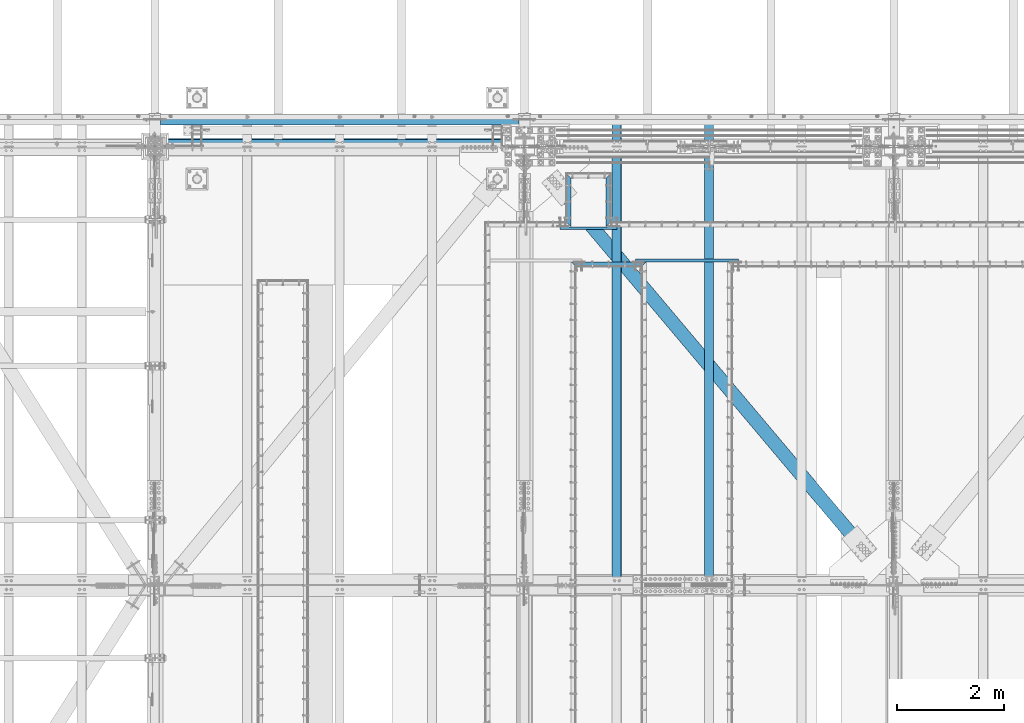
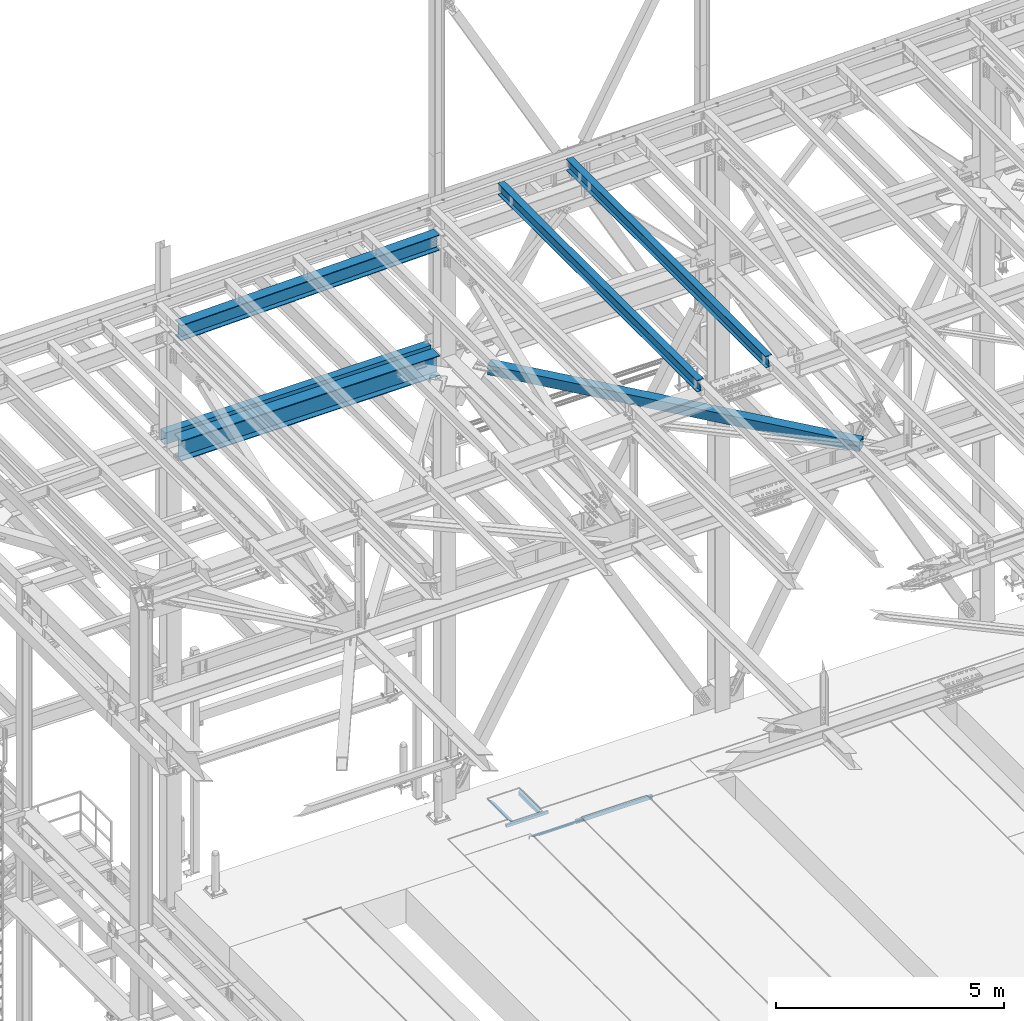
# One storey, part 1913 of 3843: 11 beams, 11 elements without a shape of their own.
"""IFC2X3 building model written with IfcOpenShell, lengths in millimetres."""

from ifc_helpers import new_model, si_unit, frame, origin_with_axes, place, context, subcontext, project, spatial, faceted_brep, material, type_object, element, aggregate, save


model = new_model("IFC2X3")

# Units and contexts
model_context = context("Model", 3, precision=1e-05, world=origin_with_axes())
body_context = subcontext(model_context, "Body", "Model", "MODEL_VIEW")
ifc_project = project(units=[si_unit("LENGTHUNIT", "METRE", prefix="MILLI"), si_unit("AREAUNIT", "SQUARE_METRE"), si_unit("VOLUMEUNIT", "CUBIC_METRE"), si_unit("MASSUNIT", "GRAM", prefix="KILO"), si_unit("TIMEUNIT", "SECOND"), si_unit("PLANEANGLEUNIT", "RADIAN"), si_unit("SOLIDANGLEUNIT", "STERADIAN"), si_unit("THERMODYNAMICTEMPERATUREUNIT", "DEGREE_CELSIUS"), si_unit("LUMINOUSINTENSITYUNIT", "LUMEN")], contexts=[model_context])

# Site, building, storey
site_placement = place(None, origin_with_axes())
site = spatial("IfcSite", under=ifc_project, at=site_placement, CompositionType="ELEMENT")
building_placement = place(site_placement, origin_with_axes())
building = spatial("IfcBuilding", under=site, at=building_placement, Name="Undefined", CompositionType="ELEMENT")
storey_placement = place(building_placement, origin_with_axes())
storey = spatial("IfcBuildingStorey", under=building, at=storey_placement, Name="Undefined", CompositionType="ELEMENT", Elevation=0.0)

# Assembly, beam
assembly_1_placement = place(storey_placement, origin_with_axes())
assembly_1 = element("IfcElementAssembly", 1, at=assembly_1_placement, inside=storey, Name="EMBED_ANGLE", AssemblyPlace="NOTDEFINED", PredefinedType="RIGID_FRAME")
ifc_material_1 = material(Name="STEEL/A36")
beam_type_1 = type_object("IfcBeamType", Name="L3-1/2X3-1/2X5/16", PredefinedType="NOTDEFINED")
beam_1_placement = place(assembly_1_placement, frame((50572.1383149553, 90709.6230245262, 30410.15), z_axis=(1.0, 0.0, 0.0), x_axis=(0.0, 1.0, 0.0)))
beam_1 = element("IfcBeam", 2, at=beam_1_placement, type_object=beam_type_1, material=ifc_material_1, Name="EMBED_ANGLE", ObjectType="L3-1/2X3-1/2X5/16", context=body_context, shape_type="Brep", body=[
    faceted_brep([(-3.63797880709171e-12, 44.4499999999971, -44.4500000000007), (88.8999999965163, 44.4499999999971, 44.4500000000007), (1003.30039015974, 44.4500000000007, 44.4500000014086), (914.400348551877, 44.4500000000007, -44.4499999987165), (88.8999958229251, 36.5125000000007, 44.4500000001353), (1003.30039015974, 36.5125000000007, 44.4500000014086), (7.93749960740388, 36.5125000000007, -36.5124999999825), (922.337852266879, 36.5125000000007, -36.512499998702), (7.93749960740388, -44.4500000000007, -36.5124999999825), (922.337852266879, -44.4500000000007, -36.512499998702), (3.63797880709171e-12, -44.4499999999971, -44.4500000000007), (914.400348551877, -44.4500000000007, -44.4499999987165)], [[[0, 1, 2, 3]], [[1, 4, 5, 2]], [[4, 6, 7, 5]], [[6, 8, 9, 7]], [[8, 10, 11, 9]], [[10, 0, 3, 11]], [[5, 7, 9, 11, 3, 2]], [[10, 8, 6, 4, 1, 0]]]),
])
aggregate(assembly_1, [beam_1])

assembly_2_placement = place(storey_placement, origin_with_axes())
assembly_2 = element("IfcElementAssembly", 3, at=assembly_2_placement, inside=storey, Name="EMBED_ANGLE", AssemblyPlace="NOTDEFINED", PredefinedType="RIGID_FRAME")
beam_2_placement = place(assembly_2_placement, frame((49822.8620576172, 90709.6230204766, 30410.15), z_axis=(0.0, 0.0, -1.0), x_axis=(0.0, 1.0, 0.0)))
beam_2 = element("IfcBeam", 4, at=beam_2_placement, type_object=beam_type_1, material=ifc_material_1, Name="EMBED_ANGLE", ObjectType="L3-1/2X3-1/2X5/16", context=body_context, shape_type="Brep", body=[
    faceted_brep([(-3.63797880709171e-12, 44.4499999999971, -44.4500000000007), (-3.63797880709171e-12, 44.4499999999971, 44.4500000000007), (914.400009086065, 44.4499999983454, 44.4500000000007), (914.400009086065, 44.4499999983454, -44.4500000000007), (7.93750032749085, 36.5124999999825, 44.4500000000007), (922.337505366435, 36.5124999983382, 44.4500000000007), (7.93749960740388, 36.5125000000007, -36.5124999999825), (922.337505366435, 36.5124999983382, -36.5125000000007), (88.9000039503298, -44.4500000001644, -36.5125000000007), (1003.2999674264, -44.4500000018088, -36.5125000000007), (88.8999999971129, -44.4500000000007, -44.4499999999971), (1003.2999674264, -44.4500000018088, -44.4500000000007)], [[[0, 1, 2, 3]], [[1, 4, 5, 2]], [[4, 6, 7, 5]], [[6, 8, 9, 7]], [[8, 10, 11, 9]], [[10, 0, 3, 11]], [[5, 7, 9, 11, 3, 2]], [[10, 8, 6, 4, 1, 0]]]),
])
aggregate(assembly_2, [beam_2])

assembly_3_placement = place(storey_placement, origin_with_axes())
assembly_3 = element("IfcElementAssembly", 5, at=assembly_3_placement, inside=storey, Name="EMBED_ANGLE", AssemblyPlace="NOTDEFINED", PredefinedType="RIGID_FRAME")
beam_3_placement = place(assembly_3_placement, frame((49867.3120686776, 90004.772703125, 30410.15), z_axis=(0.0, -1.0, 0.0), x_axis=(1.0, 0.0, 0.0)))
beam_3 = element("IfcBeam", 6, at=beam_3_placement, type_object=beam_type_1, material=ifc_material_1, Name="EMBED_ANGLE", ObjectType="L3-1/2X3-1/2X5/16", context=body_context, shape_type="Brep", body=[
    faceted_brep([(44.4499983150599, -44.4500000000007, -36.5125000001281), (44.4499999898835, -44.4500000000007, -44.4500000001281), (44.4499999898835, 36.5125000000044, -44.4500000001281), (44.4499983150599, 36.5125000000007, -36.5125000001281), (260.349999989907, 36.5125000000044, -44.4500000007247), (260.349998315098, 36.5125000000007, -36.5125000007247), (260.349998315098, -44.4499999999971, -36.5125000007247), (260.349999989907, -44.4500000000007, -44.4500000007247), (1416.11339702165, -44.4500000000007, -44.4499999969266), (1408.175895022, -44.4500000000007, -36.5124999969412), (1371.62654863185, -44.4499999999898, -36.5124999970139), (1371.62655060829, -44.4500000000007, -44.4499999970139), (1408.175895022, 36.5125000000007, -36.5124999969412), (1371.62654863185, 36.5125000000007, -36.5124999970139), (1371.62655060829, 36.5125000000116, -44.4499999970139), (1155.72654863182, 36.5125000000007, -36.5124999974796), (1155.72655060826, 36.5125000000116, -44.4499999974796), (1155.72654863182, -44.4500000000007, -36.5124999974796), (1155.72655060826, -44.4500000000007, -44.4499999974796), (3.63797880709171e-12, -44.4499999999971, -44.4500000000007), (-3.63797880709171e-12, 44.4499999999971, -44.4500000000007), (1416.11339702165, 44.4500000000007, -44.4499999969266), (7.93749960740388, -44.4500000000007, -36.5124999999825), (7.93749960740388, 36.5125000000007, -36.5124999999825), (44.4499906109268, 36.5125000000007, -2.28901626542211e-08), (88.8999958229251, 36.5125000000007, 44.4500000001353), (88.8999999965163, 44.4499999999971, 44.4500000000007), (260.349981232008, 36.5125000000007, 44.4499999992695), (1155.72652847217, 36.5125000000007, 44.4500000025146), (1327.21337462554, 36.5125000000007, 44.4500000028784), (1327.21337462554, 44.4500000000007, 44.4500000028784), (1371.62653953107, 36.5125000000007, 0.0368462862388697)], [[[0, 1, 2, 3]], [[3, 2, 4, 5]], [[6, 5, 4, 7]], [[8, 9, 10, 11]], [[9, 12, 13, 10]], [[10, 13, 14, 11]], [[15, 16, 14, 13]], [[17, 18, 16, 15]], [[18, 17, 6, 7]], [[2, 1, 19, 20, 21, 8, 11, 14, 16, 18, 7, 4]], [[22, 19, 1, 0]], [[23, 22, 0, 3]], [[19, 22, 23, 24, 25, 26, 20]], [[26, 25, 27, 28, 29, 30]], [[20, 26, 30, 21]], [[29, 31, 12, 9, 8, 21, 30]], [[28, 27, 25, 24, 23, 3, 5, 15, 13, 12, 31, 29]], [[17, 15, 5, 6]]]),
])
aggregate(assembly_3, [beam_3])

assembly_4_placement = place(storey_placement, origin_with_axes())
assembly_4 = element("IfcElementAssembly", 7, at=assembly_4_placement, inside=storey, Name="BEAM", AssemblyPlace="NOTDEFINED", PredefinedType="RIGID_FRAME")
ifc_material_2 = material(Name="STEEL/A992")
beam_type_2 = type_object("IfcBeamType", Name="W12X26", PredefinedType="NOTDEFINED")
beam_4_placement = place(assembly_4_placement, frame((52460.4092623254, 83985.2348870467, 45917.7140370369), z_axis=(-0.0211520979608104, 0.000867023000348128, 0.999775893399602), x_axis=(0.0, 0.999999623967267, -0.000867216999971372)))
beam_4 = element("IfcBeam", 8, at=beam_4_placement, type_object=beam_type_2, material=ifc_material_2, Name="BEAM", ObjectType="W12X26", context=body_context, shape_type="Brep", body=[
    faceted_brep([(8748.71732880195, -3.17499999985739, -146.05000000554), (8748.71732880197, -82.5499999997264, -146.050000005453), (8748.717328802, -82.5499999997337, -155.575000005432), (8748.717328802, 82.5500000000102, -155.575000005629), (8748.71732880197, 82.5500000000029, -146.050000005649), (8748.71732880195, 3.1750000001266, -146.050000005554), (8748.71732880168, 3.1750000001266, -142.874999989544), (8748.71732880171, -3.17499999986467, -142.87499998953), (8749.6840587242, 3.1750000001266, -138.014920471498), (8749.68405872422, -3.17499999986467, -138.014920471476), (8752.43707262463, 3.17500000013388, -133.894744003359), (8752.43707262464, -3.17499999986467, -133.894744003337), (8756.55724909274, 3.17500000013388, -131.1417301029), (8756.55724909276, -3.17499999985739, -131.141730102885), (8761.41732861078, 3.1750000001266, -130.175000180359), (8761.4173286108, -3.17499999985739, -130.175000180345), (8818.54373440972, -3.17499999985739, -130.175000181531), (8818.54385089071, 3.17500000013388, -130.175000181538), (12.4385471644346, 3.17499999999563, 146.049999999734), (12.4400031769328, 82.5499999998574, 146.049999999646), (8748.71732880328, 82.5499999999738, 146.049999993847), (8748.71732880328, 3.17500000011205, 146.049999993942), (12.6984905761929, -82.5499999998501, -155.574999999641), (12.6902321791858, -82.5499999998501, -146.049999999646), (12.6916881916841, -3.17499999998108, -146.049999999748), (12.4384306834399, -3.17500000000291, 146.049999999748), (12.4369746709563, -82.5499999998719, 146.049999999843), (12.4287162739347, -82.5499999998792, 155.574999999822), (12.4317447799258, 82.5499999998647, 155.574999999626), (12.6918046726933, 3.17500000001019, -146.049999999756), (12.6932606851769, 82.5499999998865, -146.049999999843), (12.7015190821839, 82.5499999998865, -155.574999999837), (8748.71732880326, -3.17499999987922, 146.049999993949), (8748.71732880326, -82.5499999997555, 146.049999994037), (8748.71732880324, -82.5499999997555, 155.574999994016), (8748.71732880322, 82.5499999999884, 155.574999993834), (8748.71732880329, -3.17499999987922, 142.8749996275), (8748.71732880328, 3.17500000011205, 142.874999627478), (8749.68405872592, -3.17499999987922, 138.014920109505), (8749.68405872591, 3.17500000010477, 138.01492010949), (8752.4370726264, -3.1749999998865, 133.894743641387), (8752.43707262639, 3.17500000011205, 133.89474364138), (8756.55724909451, -3.17499999987922, 131.141729740913), (8756.55724909448, 3.17500000011933, 131.141729740892), (8761.41732861249, -3.17499999987922, 130.174999818293), (8761.41732861246, 3.17500000011933, 130.174999818271), (8818.31800489149, -3.17499999987194, 130.174999818482), (8818.31812137249, 3.17500000011205, 130.174999818482), (8818.52904421304, 3.1750000001266, -113.097399678452), (8818.32910871337, 3.17500000011205, 117.5025136431)], [[[0, 1, 2, 3, 4, 5, 6, 7]], [[7, 6, 8, 9]], [[9, 8, 10, 11]], [[11, 10, 12, 13]], [[13, 12, 14, 15]], [[16, 15, 14, 17]], [[18, 19, 20, 21]], [[22, 23, 24, 25, 26, 27, 28, 19, 18, 29, 30, 31]], [[26, 25, 32, 33]], [[27, 26, 33, 34]], [[28, 27, 34, 35]], [[19, 28, 35, 20]], [[34, 33, 32, 36, 37, 21, 20, 35]], [[38, 39, 37, 36]], [[40, 41, 39, 38]], [[42, 43, 41, 40]], [[44, 45, 43, 42]], [[46, 47, 45, 44]], [[48, 49, 47, 46, 16, 17]], [[12, 10, 8, 6, 5, 29, 18, 21, 37, 39, 41, 43, 45, 47, 49, 48, 17, 14]], [[30, 29, 5, 4]], [[31, 30, 4, 3]], [[22, 31, 3, 2]], [[23, 22, 2, 1]], [[24, 23, 1, 0]], [[46, 44, 42, 40, 38, 36, 32, 25, 24, 0, 7, 9, 11, 13, 15, 16]]]),
])
aggregate(assembly_4, [beam_4])

assembly_5_placement = place(storey_placement, origin_with_axes())
assembly_5 = element("IfcElementAssembly", 9, at=assembly_5_placement, inside=storey, Name="BEAM", AssemblyPlace="NOTDEFINED", PredefinedType="RIGID_FRAME")
beam_5_placement = place(assembly_5_placement, frame((50726.8592623854, 83985.2201693133, 45880.2012236894), z_axis=(-0.0211520983200607, 0.000772419999964767, 0.999775970957495), x_axis=(0.0, 0.999999701549984, -0.000772592999652699)))
beam_5 = element("IfcBeam", 10, at=beam_5_placement, type_object=beam_type_2, material=ifc_material_2, Name="BEAM", ObjectType="W12X26", context=body_context, shape_type="Brep", body=[
    faceted_brep([(8748.71648066126, -3.17500000070868, -146.049999979092), (8748.71648066127, -82.5500000005559, -146.049999979157), (8748.71648066131, -82.5500000005704, -155.574999979166), (8748.71648066131, 82.5499999991225, -155.574999979035), (8748.71648066127, 82.5499999991371, -146.049999979019), (8748.71648066129, 3.17499999928259, -146.049999979085), (8748.71648066162, 3.17499999929714, -142.874999447537), (8748.71648066159, -3.17500000069413, -142.874999447551), (8749.68321058417, 3.17499999930442, -138.014919929454), (8749.68321058416, -3.17500000068685, -138.014919929468), (8752.43622448467, 3.17499999931169, -133.894743461256), (8752.43622448464, -3.17500000067957, -133.894743461271), (8756.55640095288, 3.17499999931169, -131.141729560753), (8756.55640095286, -3.1750000006723, -131.141729560775), (8761.41648047102, 3.17499999931897, -130.17499963817), (8761.416480471, -3.1750000006723, -130.174999638191), (8818.54545955041, -3.1750000006723, -130.174999639152), (8818.54556332191, 3.17499999931169, -130.174999639159), (12.4670743305905, 3.17500000025757, 146.050000000287), (12.4683714744315, 82.5500000001048, 146.050000000352), (8748.7164806548, 82.5499999996537, 146.050000021489), (8748.7164806548, 3.17499999980646, 146.050000021423), (12.6986547122506, -82.5500000001193, -155.57500000031), (12.6912974081351, -82.5500000001048, -146.050000000294), (12.6925945519761, -3.17500000025757, -146.050000000221), (12.4669705590786, -3.1749999997337, 146.050000000279), (12.4656734152522, -82.5499999995882, 146.050000000214), (12.4583161111223, -82.5499999995736, 155.575000000223), (12.461014170316, 82.5500000001193, 155.575000000368), (12.6926983234735, 3.1749999997337, -146.050000000221), (12.6939954673289, 82.5499999995882, -146.050000000148), (12.7013527714444, 82.5499999995736, -155.575000000172), (8748.71648065478, -3.17500000017753, 146.050000021416), (8748.71648065478, -82.5500000000393, 146.050000021351), (8748.71648065474, -82.550000000032, 155.575000021367), (8748.71648065475, 82.5499999996682, 155.575000021505), (8748.71648065526, -3.17500000018481, 142.875000172455), (8748.71648065528, 3.17499999979191, 142.875000172469), (8749.68321057789, -3.17500000019936, 138.014920654401), (8749.68321057792, 3.17499999979191, 138.014920654423), (8752.43622447843, -3.17500000021391, 133.89474418624), (8752.43622447847, 3.17499999977736, 133.894744186269), (8756.55640094666, -3.17500000022119, 131.141730285759), (8756.55640094669, 3.17499999977736, 131.141730285774), (8761.41648046476, -3.17500000021391, 130.175000363161), (8761.41648046479, 3.17499999977736, 130.175000363182), (8818.34435990457, -3.17500000022119, 130.175000362819), (8818.34446367608, 3.17499999977008, 130.175000362804), (8818.53237456725, 3.17499999934807, -113.100418205424), (8818.35425448083, 3.17499999974825, 117.499513008799)], [[[0, 1, 2, 3, 4, 5, 6, 7]], [[7, 6, 8, 9]], [[9, 8, 10, 11]], [[11, 10, 12, 13]], [[13, 12, 14, 15]], [[16, 15, 14, 17]], [[18, 19, 20, 21]], [[22, 23, 24, 25, 26, 27, 28, 19, 18, 29, 30, 31]], [[26, 25, 32, 33]], [[27, 26, 33, 34]], [[28, 27, 34, 35]], [[19, 28, 35, 20]], [[34, 33, 32, 36, 37, 21, 20, 35]], [[38, 39, 37, 36]], [[40, 41, 39, 38]], [[42, 43, 41, 40]], [[44, 45, 43, 42]], [[46, 47, 45, 44]], [[48, 49, 47, 46, 16, 17]], [[12, 10, 8, 6, 5, 29, 18, 21, 37, 39, 41, 43, 45, 47, 49, 48, 17, 14]], [[30, 29, 5, 4]], [[31, 30, 4, 3]], [[22, 31, 3, 2]], [[23, 22, 2, 1]], [[24, 23, 1, 0]], [[46, 44, 42, 40, 38, 36, 32, 25, 24, 0, 7, 9, 11, 13, 15, 16]]]),
])
aggregate(assembly_5, [beam_5])

assembly_6_placement = place(storey_placement, origin_with_axes())
assembly_6 = element("IfcElementAssembly", 11, at=assembly_6_placement, inside=storey, Name="BEAM", AssemblyPlace="NOTDEFINED", PredefinedType="RIGID_FRAME")
beam_type_3 = type_object("IfcBeamType", Name="W21X101", PredefinedType="NOTDEFINED")
beam_6_placement = place(assembly_6_placement, frame((42062.4, 92214.7, 42197.3375), z_axis=(0.0, 0.0, 1.0), x_axis=(1.0, 0.0, 0.0)))
beam_6 = element("IfcBeam", 12, at=beam_6_placement, type_object=beam_type_3, material=ifc_material_2, Name="BEAM", ObjectType="W21X101", context=body_context, shape_type="Brep", body=[
    faceted_brep([(6740.525, -155.575000000001, 250.824999999997), (6740.525, -6.34999999999854, 250.824999999997), (6740.525, 6.34999999999854, 250.824999999997), (6740.525, 155.575000000001, 250.824999999997), (6728.61039888389, 155.575000000001, 271.462500000001), (6728.61039888389, -155.575000000001, 271.462500000001), (196.850000000006, -6.34999999999854, -250.824999999997), (196.850000000006, -155.575000000001, -250.824999999997), (6737.34998277018, -155.574999999997, -250.824999999997), (6737.34998277018, -6.35000000000582, -250.824999999997), (196.850000000006, -155.575000000001, -271.462500000001), (6737.34998277018, -155.574999999997, -271.462500000001), (196.850000000006, 155.575000000001, -271.462500000001), (6737.34998277018, 155.574999999997, -271.462500000001), (196.850000000006, 155.575000000001, -250.824999999997), (196.850000000006, 6.34999999999854, -250.824999999997), (6737.34998277018, 6.35000000000582, -250.824999999997), (6737.34998277018, 155.574999999997, -250.824999999997), (196.850000000006, -6.34999999999854, 250.824999999997), (196.850000000006, -155.575000000001, 250.824999999997), (196.850000000006, -155.575000000001, 271.462500000001), (196.850000000006, 155.575000000001, 271.462500000001), (196.850000000006, 155.575000000001, 250.824999999997), (196.850000000006, 6.34999999999854, 250.824999999997), (6740.525, -6.34999999999854, 250.428), (6740.525, 6.34999999999854, 250.428), (6705.59999999999, -6.34999999999854, 250.428), (6705.59999999999, 6.34999999999854, 250.428), (6660.21509456492, -6.34999999999854, 234.406795689014), (6660.21509456492, 6.34999999999854, 234.406795689014), (6655.9257321012, -6.34999999999854, 231.347328818971), (6655.9257321012, 6.34999999999854, 231.347328818971), (6653.9188778181, -6.34999999999854, 226.475829690324), (6653.9188778181, 6.34999999999854, 226.475829690324), (6654.80856119223, -6.34999999999854, 221.282812131351), (6654.80856119223, 6.34999999999854, 221.282812131351), (6658.32256922778, -6.34999999999854, 217.357163726287), (6658.32256922778, 6.34999999999854, 217.357163726287), (6663.38573441853, -6.34999999999854, 215.900000000001), (6663.38573441853, 6.34999999999854, 215.900000000001), (6737.34998277018, -6.35000000000582, 215.900000000001), (6737.34998277018, 6.35000000000582, 215.900000000001)], [[[0, 1, 2, 3, 4, 5]], [[6, 7, 8, 9]], [[7, 10, 11, 8]], [[10, 12, 13, 11]], [[14, 15, 16, 17]], [[12, 14, 17, 13]], [[10, 7, 6, 18, 19, 20, 21, 22, 23, 15, 14, 12]], [[20, 19, 0, 5]], [[21, 20, 5, 4]], [[22, 21, 4, 3]], [[23, 22, 3, 2]], [[24, 25, 2, 1]], [[26, 27, 25, 24]], [[28, 29, 27, 26]], [[30, 31, 29, 28]], [[32, 33, 31, 30]], [[34, 35, 33, 32]], [[36, 37, 35, 34]], [[38, 39, 37, 36]], [[39, 38, 40, 41]], [[15, 23, 2, 25, 27, 29, 31, 33, 35, 37, 39, 41, 16]], [[40, 9, 8, 11, 13, 17, 16, 41]], [[38, 36, 34, 32, 30, 28, 26, 24, 1, 18, 6, 9, 40]], [[19, 18, 1, 0]]]),
])
aggregate(assembly_6, [beam_6])

assembly_7_placement = place(storey_placement, origin_with_axes())
assembly_7 = element("IfcElementAssembly", 13, at=assembly_7_placement, inside=storey, Name="GIRT", AssemblyPlace="NOTDEFINED", PredefinedType="RIGID_FRAME")
ifc_material_3 = material()
beam_type_4 = type_object("IfcBeamType", Name="HSS12X8X3/8", PredefinedType="NOTDEFINED")
beam_7_placement = place(assembly_7_placement, frame((42062.4, 92722.7, 42214.8), z_axis=(0.0, 0.0, 1.0), x_axis=(1.0, 0.0, 0.0)))
beam_7 = element("IfcBeam", 14, at=beam_7_placement, type_object=beam_type_4, material=ifc_material_3, Name="GIRT", ObjectType="HSS12X8X3/8", context=body_context, shape_type="Brep", body=[
    faceted_brep([(103.1875, 101.600000000006, -152.400000000001), (103.1875, 101.600000000006, 152.400000000001), (6831.0125, 101.600000000006, 152.400000000001), (6831.0125, 101.600000000006, -152.400000000001), (103.1875, -101.600000000006, -152.400000000001), (6831.0125, -101.600000000006, -152.400000000001), (103.1875, -101.600000000006, 152.400000000001), (6831.0125, -101.600000000006, 152.400000000001), (103.1875, 92.0749999999971, -142.875), (103.1875, 92.0749999999971, 142.875), (103.1875, -92.0749999999971, 142.875), (103.1875, -92.0749999999971, -142.875), (6831.0125, -92.0749999999971, 142.875), (6831.0125, -92.0749999999971, -142.875), (6831.0125, 92.0749999999971, -142.875), (6831.0125, 92.0749999999971, 142.875)], [[[0, 1, 2, 3]], [[4, 0, 3, 5]], [[6, 4, 5, 7]], [[1, 6, 7, 2]], [[0, 4, 6, 1], [8, 9, 10, 11]], [[11, 10, 12, 13]], [[8, 11, 13, 14]], [[9, 8, 14, 15]], [[10, 9, 15, 12]], [[3, 2, 7, 5], [14, 13, 12, 15]]]),
])
aggregate(assembly_7, [beam_7])

assembly_8_placement = place(storey_placement, origin_with_axes())
assembly_8 = element("IfcElementAssembly", 15, at=assembly_8_placement, inside=storey, AssemblyPlace="NOTDEFINED", PredefinedType="RIGID_FRAME")
beam_type_5 = type_object("IfcBeamType", Name="HSS10X10X3/4", PredefinedType="NOTDEFINED")
beam_8_placement = place(assembly_8_placement, frame((48820.8708875369, 92423.2576280741, 42246.55), z_axis=(0.764727548108142, 0.644353767091114, 0.0), x_axis=(0.644353767091114, -0.764727548108142, 0.0)))
beam_8 = element("IfcBeam", 16, at=beam_8_placement, type_object=beam_type_5, material=ifc_material_3, ObjectType="HSS10X10X3/4", context=body_context, shape_type="Brep", body=[
    faceted_brep([(1316.99973151016, 1.58750000000146, 126.999999996304), (1316.99973151016, 1.58750000000146, 107.949999996388), (1569.41223112956, 1.58750000000146, 107.949999995792), (1569.41223112963, 1.58750000000146, 126.999999995707), (1574.87982081556, 0.499928791716229, 107.949999995777), (1574.87982081563, 0.499928791716229, 126.999999995693), (1579.51501953568, -2.59721197552426, 107.949999995762), (1579.51501953575, -2.59721197552426, 126.999999995678), (1582.61216030298, -7.23241069557116, 107.949999995748), (1582.61216030304, -7.23241069557116, 126.999999995678), (1569.41223112963, -26.9874999999956, 126.999999995707), (1569.41223112956, -26.9874999999956, 107.949999995792), (1316.99973151016, -26.9874999999956, 107.949999996388), (1316.99973151016, -26.9874999999956, 126.999999996304), (1574.87982081563, -25.8999287917104, 126.999999995693), (1574.87982081556, -25.8999287917104, 107.949999995777), (1579.51501953575, -22.8027880244699, 126.999999995678), (1579.51501953568, -22.8027880244699, 107.949999995762), (1582.61216030304, -18.167589304423, 126.999999995678), (1582.61216030298, -18.167589304423, 107.949999995748), (1583.69973151135, -12.6999996185259, 126.999999995678), (1583.69973151127, -12.6999996185259, 107.949999995762), (1316.99973150995, 1.58750000000146, -107.950000002616), (1316.99973150995, 1.58750000000146, -127.000000002547), (1569.4122311286, 1.58750000000146, -127.000000003143), (1569.41223112866, 1.58750000000146, -107.950000003213), (1574.87982081458, 0.499928791716229, -127.000000003158), (1574.87982081465, 0.499928791716229, -107.950000003228), (1579.5150195347, -2.59721197552426, -127.000000003158), (1579.51501953479, -2.59721197552426, -107.950000003242), (1582.612160302, -7.23241069557116, -127.000000003158), (1582.61216030208, -7.23241069557116, -107.950000003257), (1569.41223112866, -26.9874999999956, -107.950000003213), (1569.4122311286, -26.9874999999956, -127.000000003143), (1316.99973150995, -26.9874999999956, -127.000000002547), (1316.99973150995, -26.9874999999956, -107.950000002616), (1574.87982081465, -25.8999287917104, -107.950000003228), (1574.87982081458, -25.8999287917104, -127.000000003158), (1579.51501953479, -22.8027880244699, -107.950000003242), (1579.5150195347, -22.8027880244699, -127.000000003158), (1582.61216030208, -18.167589304423, -107.950000003257), (1582.612160302, -18.167589304423, -127.000000003158), (1583.69973151039, -12.6999996185259, -107.950000003257), (1583.6997315103, -12.6999996185259, -127.000000003172), (1316.99973151016, 107.949999999997, 107.949999996388), (1316.99973150995, 107.949999999997, -107.950000002616), (9989.92294845253, 107.949999999997, -107.950000023164), (9989.92294845272, 107.949999999997, 107.94999997587), (1316.99973150995, 127.0, -127.000000002547), (9989.92294845251, 127.0, -127.000000023065), (9989.92294845251, 1.58750000138389, -127.000000023065), (9737.51044893522, 1.58750000007421, -127.000000022483), (9732.04285924925, 0.499928791781713, -127.000000022454), (9727.40766052917, -2.5972119754515, -127.000000022454), (9724.31051976189, -7.23241069546202, -127.000000022454), (9723.22294855357, -12.6999996237719, -127.000000022439), (9724.31051976186, -18.1675893097054, -127.000000022439), (9727.40766052917, -22.8027880297886, -127.000000022454), (9732.04285924932, -25.8999287970437, -127.000000022454), (9737.51044893535, -26.9875000053144, -127.000000022483), (9989.92294845251, -26.9875000040047, -127.000000023065), (9989.92294845251, -127.0, -127.000000023065), (1316.99973150995, -127.0, -127.000000002547), (9989.92294845253, 1.58750000138389, -107.950000023164), (9737.5104489353, 1.58750000007421, -107.950000022553), (9732.04285924933, 0.499928791781713, -107.950000022553), (9727.40766052924, -2.5972119754515, -107.950000022538), (9724.31051976197, -7.23241069546202, -107.950000022523), (9723.22294855365, -12.6999996237719, -107.950000022523), (9724.31051976194, -18.1675893097054, -107.950000022523), (9727.40766052924, -22.8027880297886, -107.950000022538), (9732.04285924941, -25.8999287970437, -107.950000022553), (9737.51044893544, -26.9875000053144, -107.950000022553), (9989.92294845253, -26.9875000040047, -107.950000023164), (1316.99973150995, -107.949999999997, -107.950000002616), (1316.99973151016, -107.949999999997, 107.949999996388), (9989.92294845272, -107.949999999997, 107.94999997587), (9989.92294845253, -107.949999999997, -107.950000023164), (9732.04285925032, 0.499928791781713, 126.999999976382), (9732.04285925023, 0.499928791781713, 107.949999976481), (9737.51044893618, 1.58750000007421, 107.949999976452), (9737.51044893626, 1.58750000007421, 126.999999976368), (9727.40766053022, -2.5972119754515, 126.999999976382), (9727.40766053015, -2.5972119754515, 107.949999976481), (9724.31051976293, -7.23241069546202, 126.999999976411), (9724.31051976285, -7.23241069546202, 107.949999976481), (9723.22294855462, -12.6999996237719, 126.999999976397), (9723.22294855454, -12.6999996237719, 107.949999976496), (9724.31051976291, -18.1675893097054, 126.999999976397), (9724.31051976282, -18.1675893097054, 107.949999976496), (9727.40766053022, -22.8027880297886, 126.999999976382), (9727.40766053015, -22.8027880297886, 107.949999976481), (9732.04285925037, -25.8999287970437, 126.999999976382), (9732.0428592503, -25.8999287970437, 107.949999976481), (9737.51044893641, -26.9875000053144, 126.999999976368), (9737.51044893632, -26.9875000053144, 107.949999976452), (9989.92294845274, -26.9875000040047, 126.999999975771), (9989.92294845272, -26.9875000040047, 107.94999997587), (9989.92294845274, -127.0, 126.999999975771), (1316.99973151016, -127.0, 126.999999996304), (9989.92294845272, 1.58750000138389, 107.94999997587), (9989.92294845274, 1.58750000138389, 126.999999975771), (9989.92294845274, 127.0, 126.999999975771), (1316.99973151016, 127.0, 126.999999996304)], [[[0, 1, 2, 3]], [[3, 2, 4, 5]], [[5, 4, 6, 7]], [[7, 6, 8, 9]], [[10, 11, 12, 13]], [[14, 15, 11, 10]], [[16, 17, 15, 14]], [[18, 19, 17, 16]], [[20, 21, 19, 18]], [[9, 8, 21, 20]], [[22, 23, 24, 25]], [[25, 24, 26, 27]], [[27, 26, 28, 29]], [[29, 28, 30, 31]], [[32, 33, 34, 35]], [[36, 37, 33, 32]], [[38, 39, 37, 36]], [[40, 41, 39, 38]], [[42, 43, 41, 40]], [[31, 30, 43, 42]], [[44, 45, 46, 47]], [[28, 26, 24, 23, 48, 49, 50, 51, 52, 53, 54, 55, 56, 57, 58, 59, 60, 61, 62, 34, 33, 37, 39, 41, 43, 30]], [[63, 64, 51, 50]], [[65, 52, 51, 64]], [[66, 53, 52, 65]], [[67, 54, 53, 66]], [[68, 55, 54, 67]], [[69, 56, 55, 68]], [[70, 57, 56, 69]], [[71, 58, 57, 70]], [[72, 59, 58, 71]], [[73, 60, 59, 72]], [[74, 75, 76, 77]], [[78, 79, 80, 81]], [[82, 83, 79, 78]], [[84, 85, 83, 82]], [[86, 87, 85, 84]], [[88, 89, 87, 86]], [[90, 91, 89, 88]], [[92, 93, 91, 90]], [[94, 95, 93, 92]], [[96, 97, 95, 94]], [[98, 61, 60, 73, 77, 76, 97, 96]], [[99, 62, 61, 98]], [[75, 74, 35, 34, 62, 99, 13, 12]], [[6, 4, 2, 1, 44, 47, 100, 80, 79, 83, 85, 87, 89, 91, 93, 95, 97, 76, 75, 12, 11, 15, 17, 19, 21, 8]], [[101, 81, 80, 100]], [[47, 46, 63, 50, 49, 102, 101, 100]], [[48, 103, 102, 49]], [[16, 14, 10, 13, 99, 98, 96, 94, 92, 90, 88, 86, 84, 82, 78, 81, 101, 102, 103, 0, 3, 5, 7, 9, 20, 18]], [[103, 48, 23, 22, 45, 44, 1, 0]], [[38, 36, 32, 35, 74, 77, 73, 72, 71, 70, 69, 68, 67, 66, 65, 64, 63, 46, 45, 22, 25, 27, 29, 31, 42, 40]]]),
])
aggregate(assembly_8, [beam_8])

assembly_9_placement = place(storey_placement, origin_with_axes())
assembly_9 = element("IfcElementAssembly", 17, at=assembly_9_placement, inside=storey, Name="BEAM", AssemblyPlace="NOTDEFINED", PredefinedType="RIGID_FRAME")
beam_type_6 = type_object("IfcBeamType", Name="W16X67", PredefinedType="NOTDEFINED")
beam_9_placement = place(assembly_9_placement, frame((42066.7988431124, 92214.7, 45326.5338700332), z_axis=(-0.0211520980073474, 0.0, 0.999776269347241), x_axis=(0.999776270257024, 0.0, 0.0211520550054619)))
beam_9 = element("IfcBeam", 18, at=beam_9_placement, type_object=beam_type_6, material=ifc_material_2, Name="BEAM", ObjectType="W16X67", context=body_context, shape_type="Brep", body=[
    faceted_brep([(188.094396478875, -130.174999999999, -207.962499999492), (188.094396478875, 130.174999999999, -207.962499999492), (6730.05803391119, 130.174999999999, -207.9624999929), (6730.05803391119, -130.174999999999, -207.9624999929), (188.463847647872, -130.174999999999, -190.49999999952), (188.463847647872, -4.76250000000073, -190.49999999952), (189.242288995723, -4.76249999999709, -153.706144372947), (195.989385218127, -4.76249999999709, 165.202490022399), (196.524600426201, -4.76250000000073, 190.499999999869), (196.524600426201, -130.174999999999, 190.499999999869), (196.894051595213, -130.174999999999, 207.962499999841), (196.894051595213, 130.174999999999, 207.962499999841), (196.524600426201, 130.174999999999, 190.499999999869), (196.524600426201, 4.76250000000073, 190.499999999869), (188.463847647872, 4.76250000000073, -190.49999999952), (188.463847647872, 130.174999999999, -190.49999999952), (6730.4274850802, -130.174999999999, -190.499999992935), (6730.4274850802, -4.76250000000073, -190.499999992935), (6731.16614278882, -4.76249999999709, -155.586565885453), (6737.91323901118, -4.76249999999709, 163.322068509893), (6738.48823785847, -4.76250000000073, 190.500000006461), (6738.48823785847, -130.174999999999, 190.500000006461), (6738.85768902747, -130.174999999999, 207.962500006433), (6738.85768902747, 130.174999999999, 207.962500006433), (6738.48823785847, 130.174999999999, 190.500000006461), (6738.48823785847, 4.76250000000073, 190.500000006461), (6730.4274850802, 4.76250000000073, -190.499999992935), (6730.4274850802, 130.174999999999, -190.499999992935)], [[[0, 1, 2, 3]], [[0, 4, 5, 6, 7, 8, 9, 10, 11, 12, 13, 14, 15, 1]], [[5, 4, 16, 17]], [[8, 7, 6, 5, 17, 18, 19, 20]], [[9, 8, 20, 21]], [[10, 9, 21, 22]], [[11, 10, 22, 23]], [[12, 11, 23, 24]], [[13, 12, 24, 25]], [[14, 13, 25, 26]], [[15, 14, 26, 27]], [[1, 15, 27, 2]], [[26, 25, 24, 23, 22, 21, 20, 19, 18, 17, 16, 3, 2, 27]], [[4, 0, 3, 16]]]),
])
aggregate(assembly_9, [beam_9])

assembly_10_placement = place(storey_placement, origin_with_axes())
assembly_10 = element("IfcElementAssembly", 19, at=assembly_10_placement, inside=storey, Name="COVER PLATE", AssemblyPlace="NOTDEFINED", PredefinedType="RIGID_FRAME")
beam_type_7 = type_object("IfcBeamType", PredefinedType="NOTDEFINED")
beam_10_placement = place(assembly_10_placement, frame((49664.1120576172, 90684.2230224609, 30416.5), z_axis=(0.0, 0.0, 1.0), x_axis=(1.0, 0.0, 0.0)))
beam_10 = element("IfcBeam", 20, at=beam_10_placement, type_object=beam_type_7, material=ifc_material_1, Name="COVER PLATE", context=body_context, shape_type="Brep", body=[
    faceted_brep([(0.0, 25.4000000000015, -38.0999999999985), (0.0, 25.4000000000015, 38.0999999999985), (1066.79998437835, 25.3999999999942, 38.0999999999985), (1066.79998437835, 25.3999999999942, -38.0999999999985), (0.0, -25.4000000000015, 38.0999999999985), (1066.79998437835, -25.3999999999942, 38.0999999999985), (0.0, -25.4000000000015, -38.0999999999985), (1066.79998437835, -25.3999999999942, -38.0999999999985)], [[[0, 1, 2, 3]], [[1, 4, 5, 2]], [[4, 6, 7, 5]], [[6, 0, 3, 7]], [[5, 7, 3, 2]], [[6, 4, 1, 0]]]),
])
aggregate(assembly_10, [beam_10])

assembly_11_placement = place(storey_placement, origin_with_axes())
assembly_11 = element("IfcElementAssembly", 21, at=assembly_11_placement, inside=storey, Name="COVER PLATE", AssemblyPlace="NOTDEFINED", PredefinedType="RIGID_FRAME")
beam_type_8 = type_object("IfcBeamType", PredefinedType="NOTDEFINED")
beam_11_placement = place(assembly_11_placement, frame((51080.1615744054, 90074.6231429596, 30403.8), z_axis=(0.0, 0.0, 1.0), x_axis=(1.0, 0.0, 0.0)))
beam_11 = element("IfcBeam", 22, at=beam_11_placement, type_object=beam_type_8, material=ifc_material_1, Name="COVER PLATE", context=body_context, shape_type="Brep", body=[
    faceted_brep([(6.54836185276508e-11, 25.4000000000087, -50.7999999999993), (6.54836185276508e-11, 25.4000000000087, 50.7999999999993), (1930.40032324089, 25.4000000105443, 50.7999999999993), (1930.40032324089, 25.4000000105443, -50.7999999999993), (-2.91038304567337e-11, -25.3999999999942, 50.7999999999993), (1930.40032324079, -25.3999999894731, 50.7999999999993), (-2.91038304567337e-11, -25.3999999999942, -50.7999999999993), (1930.40032324079, -25.3999999894731, -50.7999999999993)], [[[0, 1, 2, 3]], [[1, 4, 5, 2]], [[4, 6, 7, 5]], [[6, 0, 3, 7]], [[5, 7, 3, 2]], [[6, 4, 1, 0]]]),
])
aggregate(assembly_11, [beam_11])

save(model, "model.ifc")
